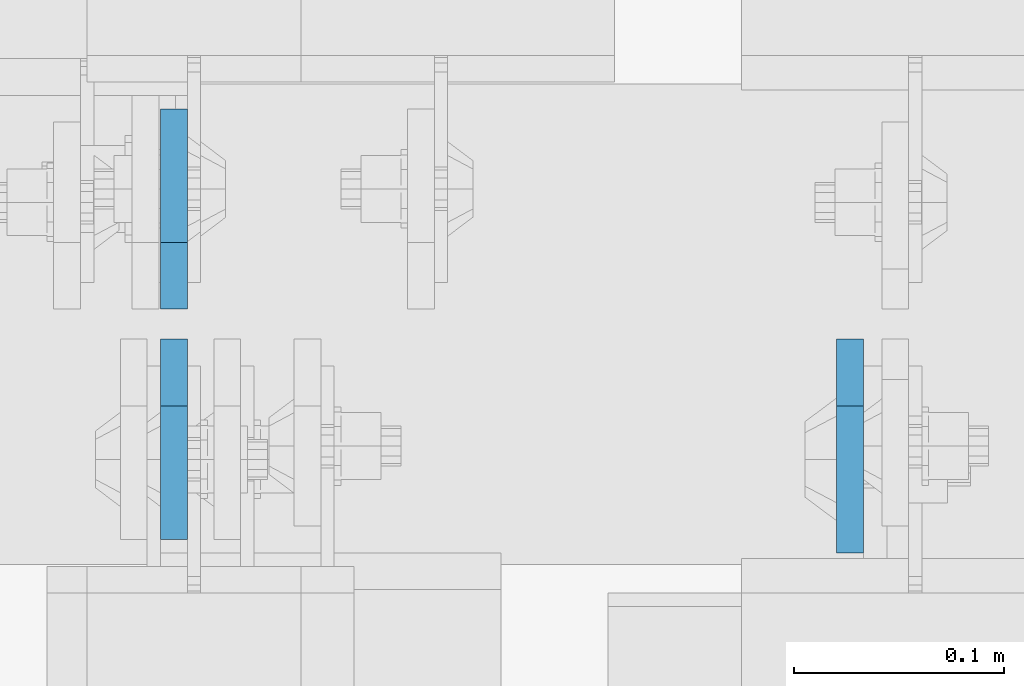
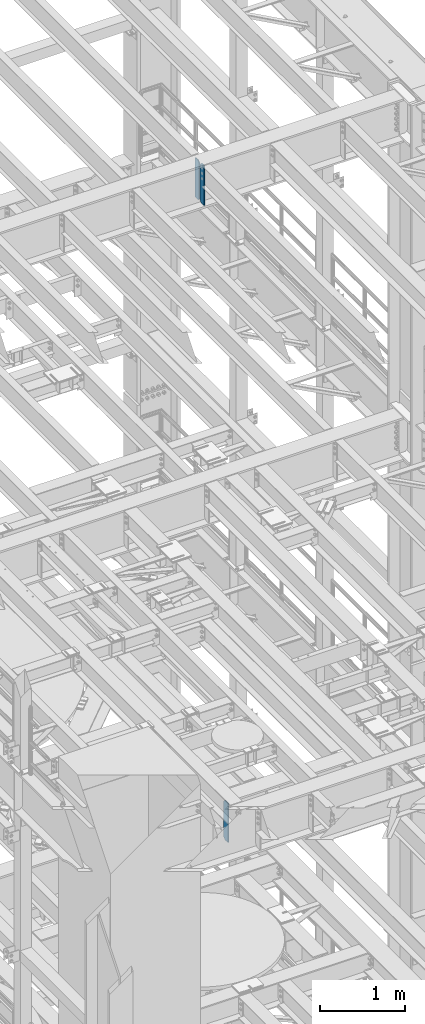
# One storey, part 1723 of 1876: 3 plates, 2 elements without a shape of their own.
"""IFC2X3 building model written with IfcOpenShell, lengths in millimetres."""

import ifcopenshell
import ifcopenshell.guid

model = None  # the IFC model being written
_history = None  # IfcOwnerHistory: only IFC2X3 demands one
_inside = {}  # id of a spatial element -> (the spatial element, [elements in it])
_under = {}  # id of a project, library or spatial element -> (it, [spatial elements below it])
_declared = {}  # id of a project -> (the project, [libraries it declares])
_typed = {}  # id of a type object -> (the type object, [elements of that type])
_made_of = {}  # id of a material, layer set ... -> (it, [elements and type objects made of it])


def new_model(schema):
    """Start an empty IFC model of exactly this schema.

    Asked for "IFC4X3", IfcOpenShell would pick the latest addendum, in which some entities
    have other attributes; the version numbers below select the first issue.
    IFC2X3 requires an IfcOwnerHistory on every rooted entity: one is made here for all.
    """
    global model, _history
    if schema == "IFC4X3":
        model = ifcopenshell.file(schema_version=(4, 3, 0, 0))
    else:
        model = ifcopenshell.file(schema=schema)
    _inside.clear()
    _under.clear()
    _declared.clear()
    _typed.clear()
    _made_of.clear()
    _history = None
    if model.schema == "IFC2X3":
        org = make("IfcOrganization", Name="unknown")
        user = make(
            "IfcPersonAndOrganization",
            ThePerson=make("IfcPerson", FamilyName="unknown"),
            TheOrganization=org,
        )
        app = make(
            "IfcApplication",
            ApplicationDeveloper=org,
            Version="unknown",
            ApplicationFullName="unknown",
            ApplicationIdentifier="unknown",
        )
        _history = make(
            "IfcOwnerHistory",
            OwningUser=user,
            OwningApplication=app,
            ChangeAction="ADDED",
            CreationDate=0,
        )
    return model


def make(cls, **values):
    """One entity of the class cls with the attributes given. An attribute that is None is left unset."""
    return model.create_entity(
        cls, **{name: value for name, value in values.items() if value is not None}
    )


def rooted(cls, **values):
    """An entity with a GlobalId (a new one), such as an element, a storey or a relation."""
    return make(cls, GlobalId=ifcopenshell.guid.new(), OwnerHistory=_history, **values)


def si_unit(unit_type, name, prefix=None):
    """IfcSIUnit, for example si_unit("LENGTHUNIT", "METRE", prefix="MILLI")."""
    return make("IfcSIUnit", UnitType=unit_type, Prefix=prefix, Name=name)


def assignment(units):
    """IfcUnitAssignment: the units of a project."""
    return None if units is None else make("IfcUnitAssignment", Units=units)


def point(xyz):
    """IfcCartesianPoint."""
    return None if xyz is None else make("IfcCartesianPoint", Coordinates=xyz)


def direction(xyz):
    """IfcDirection."""
    return None if xyz is None else make("IfcDirection", DirectionRatios=xyz)


def frame(location, z_axis=None, x_axis=None):
    """IfcAxis2Placement3D, a coordinate frame: its origin and axes. An axis left out is left unset."""
    return make(
        "IfcAxis2Placement3D",
        Location=point(location),
        Axis=direction(z_axis),
        RefDirection=direction(x_axis),
    )


def origin_with_axes():
    """The frame at (0, 0, 0) with the z axis (0, 0, 1) and the x axis (1, 0, 0) written out."""
    return frame((0.0, 0.0, 0.0), z_axis=(0.0, 0.0, 1.0), x_axis=(1.0, 0.0, 0.0))


def place(relative_to, where):
    """IfcLocalPlacement: puts the frame where relative to a parent placement (None: the world)."""
    return make(
        "IfcLocalPlacement", PlacementRelTo=relative_to, RelativePlacement=where
    )


def context(
    kind, dimensions, precision=None, world=None, true_north=None, identifier=None
):
    """IfcGeometricRepresentationContext, for example the 3D "Model" context."""
    return make(
        "IfcGeometricRepresentationContext",
        ContextIdentifier=identifier,
        ContextType=kind,
        CoordinateSpaceDimension=dimensions,
        Precision=precision,
        WorldCoordinateSystem=world,
        TrueNorth=true_north,
    )


def subcontext(parent, identifier, kind, view, scale=None):
    """IfcGeometricRepresentationSubContext, for example "Body" below "Model"."""
    return make(
        "IfcGeometricRepresentationSubContext",
        ContextIdentifier=identifier,
        ContextType=kind,
        ParentContext=parent,
        TargetScale=scale,
        TargetView=view,
    )


def project(units=None, contexts=None):
    """IfcProject with its units and contexts."""
    return rooted(
        "IfcProject",
        Name="project",
        RepresentationContexts=contexts,
        UnitsInContext=assignment(units),
    )


def spatial(cls, under=None, at=None, **own):
    """A site, building, storey or space (cls), placed at a placement, below another one or the project."""
    s = rooted(cls, ObjectPlacement=at, **own)
    if under is not None:
        _under.setdefault(under.id(), (under, []))[1].append(s)
    return s


def faces_of(points, faces, orient=None, outer=None):
    """IfcFace entities. A face is a list of loops; a loop is a list of indices into points, from 0.

    orient and outer hold one flag for each loop. By default every Orientation is true, the
    first loop of a face is its IfcFaceOuterBound and the others are IfcFaceBound.
    """
    made = []
    for i, loops in enumerate(faces):
        bounds = []
        for j, loop in enumerate(loops):
            is_outer = j == 0 if outer is None else outer[i][j]
            bounds.append(
                make(
                    "IfcFaceOuterBound" if is_outer else "IfcFaceBound",
                    Bound=make("IfcPolyLoop", Polygon=[points[k] for k in loop]),
                    Orientation=True if orient is None else orient[i][j],
                )
            )
        made.append(make("IfcFace", Bounds=bounds))
    return made


def faceted_brep(points, faces, orient=None, outer=None, voids=None):
    """IfcFacetedBrep: a solid bounded by flat faces; with voids (closed shells), ...WithVoids."""
    shared = [point(p) for p in points]
    hull = make("IfcClosedShell", CfsFaces=faces_of(shared, faces, orient, outer))
    if voids is None:
        return make("IfcFacetedBrep", Outer=hull)
    return make(
        "IfcFacetedBrepWithVoids",
        Outer=hull,
        Voids=[
            make(cls, CfsFaces=faces_of(shared, fs, o, b)) for cls, fs, o, b in voids
        ],
    )


def shape(context_of_items, identifier, shape_type, items):
    """IfcShapeRepresentation: the items that make up one representation, for example the "Body"."""
    return make(
        "IfcShapeRepresentation",
        ContextOfItems=context_of_items,
        RepresentationIdentifier=identifier,
        RepresentationType=shape_type,
        Items=items,
    )


def material(Name=None, Category=None):
    """IfcMaterial."""
    return make("IfcMaterial", Name=Name, Category=Category)


def made_of(thing, what):
    """Note that an element or type object is made of a material, layer set ...; save() writes the relation."""
    if what is not None:
        _made_of.setdefault(what.id(), (what, []))[1].append(thing)
    return thing


def type_object(cls, material=None, **own):
    """A type object (cls), such as IfcWallType, which elements share."""
    return made_of(rooted(cls, **own), material)


def element(
    cls,
    number,
    at=None,
    inside=None,
    cuts=None,
    type_object=None,
    material=None,
    context=None,
    identifier="Body",
    shape_type=None,
    held_by="IfcProductDefinitionShape",
    body=None,
    shapes=None,
    **own,
):
    """One element of the class cls, such as IfcWall. Its Tag is "e" and its number.

    at: its placement. inside: the storey or other place that contains it. cuts: it is an
    opening in that element (IfcRelVoidsElement). A single representation is given by context,
    identifier, shape_type and body (its items); several are given by shapes. held_by: the class
    of the entity that holds the representations. save() writes the other relations.
    """
    e = rooted(cls, Tag="e%d" % number, ObjectPlacement=at, **own)
    if body is not None:
        shapes = [shape(context, identifier, shape_type, body)]
    if shapes is not None:
        e.Representation = make(held_by, Representations=shapes)
    if inside is not None:
        _inside.setdefault(inside.id(), (inside, []))[1].append(e)
    if cuts is not None:
        rooted(
            "IfcRelVoidsElement", RelatingBuildingElement=cuts, RelatedOpeningElement=e
        )
    if type_object is not None:
        _typed.setdefault(type_object.id(), (type_object, []))[1].append(e)
    return made_of(e, material)


def aggregate(whole, parts):
    """IfcRelAggregates: a whole, such as a stair, and the parts it consists of."""
    return rooted("IfcRelAggregates", RelatingObject=whole, RelatedObjects=parts)


def save(model, path):
    """Write the relations noted so far, then the file.

    IfcRelAggregates (storeys below a building ...), IfcRelContainedInSpatialStructure (elements
    in a storey), IfcRelDefinesByType, IfcRelAssociatesMaterial and IfcRelDeclares: one each for
    every whole, place, type object, material and project.
    """
    for whole, parts in _under.values():
        aggregate(whole, parts)
    for where, things in _inside.values():
        rooted(
            "IfcRelContainedInSpatialStructure",
            RelatedElements=things,
            RelatingStructure=where,
        )
    for kind, things in _typed.values():
        rooted("IfcRelDefinesByType", RelatedObjects=things, RelatingType=kind)
    for what, things in _made_of.values():
        rooted("IfcRelAssociatesMaterial", RelatedObjects=things, RelatingMaterial=what)
    for by, libraries in _declared.values():
        rooted("IfcRelDeclares", RelatingContext=by, RelatedDefinitions=libraries)
    model.write(path)


model = new_model("IFC2X3")

# Units and contexts
model_context = context("Model", 3, precision=1e-05, world=origin_with_axes())
body_context = subcontext(model_context, "Body", "Model", "MODEL_VIEW")
ifc_project = project(units=[si_unit("LENGTHUNIT", "METRE", prefix="MILLI"), si_unit("AREAUNIT", "SQUARE_METRE"), si_unit("VOLUMEUNIT", "CUBIC_METRE"), si_unit("MASSUNIT", "GRAM", prefix="KILO"), si_unit("TIMEUNIT", "SECOND"), si_unit("PLANEANGLEUNIT", "RADIAN"), si_unit("SOLIDANGLEUNIT", "STERADIAN"), si_unit("THERMODYNAMICTEMPERATUREUNIT", "DEGREE_CELSIUS"), si_unit("LUMINOUSINTENSITYUNIT", "LUMEN")], contexts=[model_context])

# Site, building, storey
site_placement = place(None, origin_with_axes())
site = spatial("IfcSite", under=ifc_project, at=site_placement, CompositionType="ELEMENT")
building_placement = place(site_placement, origin_with_axes())
building = spatial("IfcBuilding", under=site, at=building_placement, Name="Undefined", CompositionType="ELEMENT")
storey_placement = place(building_placement, origin_with_axes())
storey = spatial("IfcBuildingStorey", under=building, at=storey_placement, Name="Undefined", CompositionType="ELEMENT", Elevation=0.0)

# Assembly, plates
assembly_1_placement = place(storey_placement, origin_with_axes())
assembly_1 = element("IfcElementAssembly", 1, at=assembly_1_placement, inside=storey, Name="BEAM", AssemblyPlace="NOTDEFINED", PredefinedType="RIGID_FRAME")
ifc_material = material(Name="STEEL/A36")
plate_type_1 = type_object("IfcPlateType", PredefinedType="NOTDEFINED")
plate_1_placement = place(assembly_1_placement, frame((4752.97499990463, 7612.85625, 21959.8875), z_axis=(0.0, 0.0, 1.0), x_axis=(0.0, -1.0, 0.0)))
plate_1 = element("IfcPlate", 2, at=plate_1_placement, type_object=plate_type_1, material=ifc_material, Name="PLATE", context=body_context, shape_type="Brep", body=[
    faceted_brep([(0.0, -6.34999999999991, 31.75), (0.0, -6.35000000000036, 538.162475585938), (0.0, 6.35000000000036, 538.162475585938), (0.0, 6.34999999999991, 31.75), (31.75, -6.35000000000036, 569.912475585938), (31.75, 6.35000000000036, 569.912475585938), (95.25, -6.35000000000036, 569.912475585938), (95.25, 6.35000000000036, 569.912475585938), (95.25, -6.35000000000036, 0.0), (95.25, 6.35000000000036, 0.0), (31.75, -6.34999999999991, 0.0), (31.75, 6.34999999999991, 0.0)], [[[0, 1, 2, 3]], [[1, 4, 5, 2]], [[4, 6, 7, 5]], [[6, 8, 9, 7]], [[8, 10, 11, 9]], [[10, 0, 3, 11]], [[5, 7, 9, 11, 3, 2]], [[10, 8, 6, 4, 1, 0]]]),
])
plate_2_placement = place(assembly_1_placement, frame((4752.97499990463, 7627.14375, 21959.8875), z_axis=(0.0, 0.0, 1.0), x_axis=(0.0, 1.0, 0.0)))
plate_2 = element("IfcPlate", 3, at=plate_2_placement, type_object=plate_type_1, material=ifc_material, Name="PLATE", context=body_context, shape_type="Brep", body=[
    faceted_brep([(0.0, -6.34999999999991, 31.75), (0.0, -6.35000000000036, 538.162475585938), (0.0, 6.35000000000036, 538.162475585938), (0.0, 6.34999999999991, 31.75), (31.75, -6.35000000000036, 569.912475585938), (31.75, 6.35000000000036, 569.912475585938), (95.25, -6.35000000000036, 569.912475585938), (95.25, 6.35000000000036, 569.912475585938), (95.25, -6.35000000000036, 0.0), (95.25, 6.35000000000036, 0.0), (31.75, -6.34999999999991, 0.0), (31.75, 6.34999999999991, 0.0)], [[[0, 1, 2, 3]], [[1, 4, 5, 2]], [[4, 6, 7, 5]], [[6, 8, 9, 7]], [[8, 10, 11, 9]], [[10, 0, 3, 11]], [[5, 7, 9, 11, 3, 2]], [[10, 8, 6, 4, 1, 0]]]),
])
aggregate(assembly_1, [plate_1, plate_2])

# Assembly, plate
assembly_2_placement = place(storey_placement, origin_with_axes())
assembly_2 = element("IfcElementAssembly", 4, at=assembly_2_placement, inside=storey, Name="BEAM", AssemblyPlace="NOTDEFINED", PredefinedType="RIGID_FRAME")
plate_type_2 = type_object("IfcPlateType", PredefinedType="NOTDEFINED")
plate_3_placement = place(assembly_2_placement, frame((5074.44374990463, 7612.85625, 12714.2875), z_axis=(0.0, 0.0, 1.0), x_axis=(0.0, -1.0, 0.0)))
plate_3 = element("IfcPlate", 5, at=plate_3_placement, type_object=plate_type_2, material=ifc_material, Name="PLATE", context=body_context, shape_type="Brep", body=[
    faceted_brep([(0.0, -6.34999999999991, 31.75), (0.0, -6.35000000000036, 538.162475585938), (0.0, 6.35000000000036, 538.162475585938), (0.0, 6.34999999999991, 31.75), (31.75, -6.35000000000036, 569.912475585938), (31.75, 6.35000000000036, 569.912475585938), (101.599998474121, -6.34999999999991, 569.912475585938), (101.599998474121, 6.34999999999991, 569.912475585938), (101.599998474121, -6.35000000000036, 0.0), (101.599998474121, 6.35000000000036, 0.0), (31.75, -6.34999999999991, 0.0), (31.75, 6.34999999999991, 0.0)], [[[0, 1, 2, 3]], [[1, 4, 5, 2]], [[4, 6, 7, 5]], [[6, 8, 9, 7]], [[8, 10, 11, 9]], [[10, 0, 3, 11]], [[5, 7, 9, 11, 3, 2]], [[10, 8, 6, 4, 1, 0]]]),
])
aggregate(assembly_2, [plate_3])

save(model, "model.ifc")
